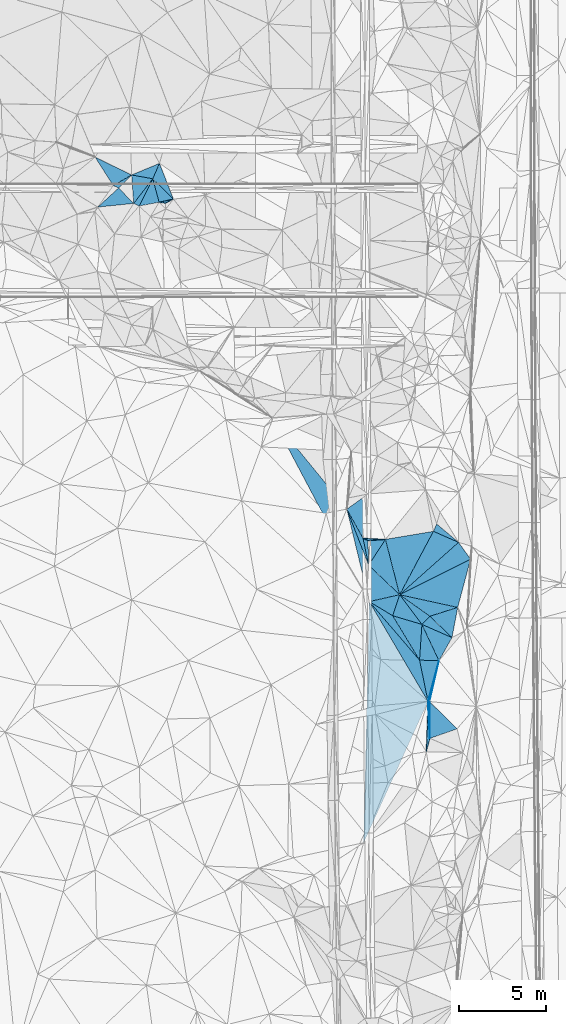
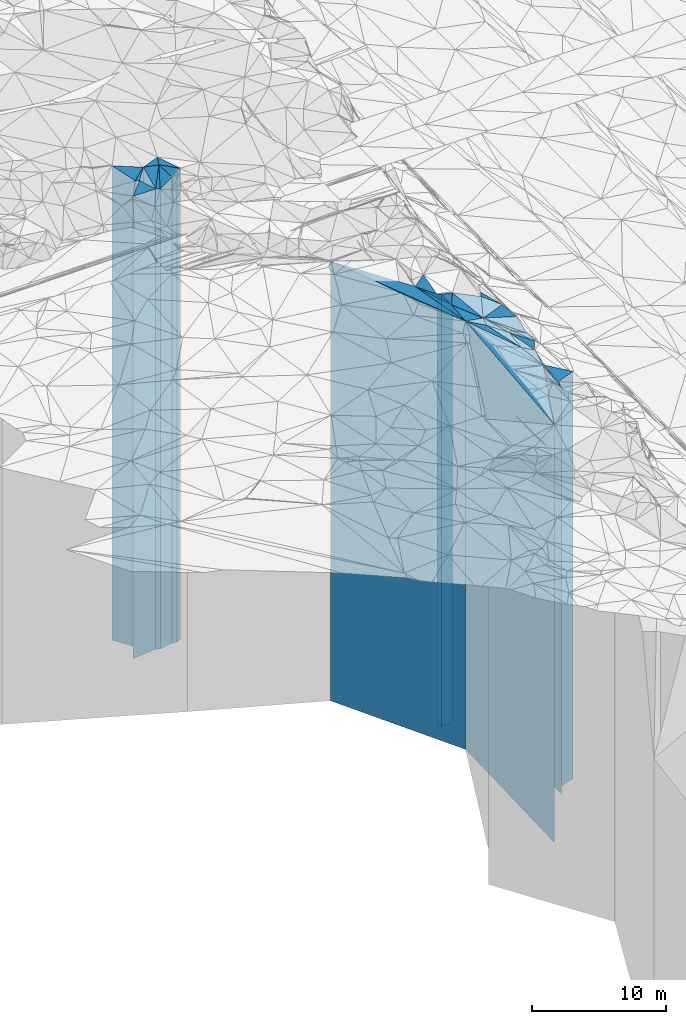
# One storey, part 206 of 275: 41 plates.
"""IFC2X3 building model written with IfcOpenShell, lengths in millimetres."""

import ifcopenshell
import ifcopenshell.guid

model = None  # the IFC model being written
_history = None  # IfcOwnerHistory: only IFC2X3 demands one
_inside = {}  # id of a spatial element -> (the spatial element, [elements in it])
_under = {}  # id of a project, library or spatial element -> (it, [spatial elements below it])
_declared = {}  # id of a project -> (the project, [libraries it declares])
_typed = {}  # id of a type object -> (the type object, [elements of that type])
_made_of = {}  # id of a material, layer set ... -> (it, [elements and type objects made of it])


def new_model(schema):
    """Start an empty IFC model of exactly this schema.

    Asked for "IFC4X3", IfcOpenShell would pick the latest addendum, in which some entities
    have other attributes; the version numbers below select the first issue.
    IFC2X3 requires an IfcOwnerHistory on every rooted entity: one is made here for all.
    """
    global model, _history
    if schema == "IFC4X3":
        model = ifcopenshell.file(schema_version=(4, 3, 0, 0))
    else:
        model = ifcopenshell.file(schema=schema)
    _inside.clear()
    _under.clear()
    _declared.clear()
    _typed.clear()
    _made_of.clear()
    _history = None
    if model.schema == "IFC2X3":
        org = make("IfcOrganization", Name="unknown")
        user = make(
            "IfcPersonAndOrganization",
            ThePerson=make("IfcPerson", FamilyName="unknown"),
            TheOrganization=org,
        )
        app = make(
            "IfcApplication",
            ApplicationDeveloper=org,
            Version="unknown",
            ApplicationFullName="unknown",
            ApplicationIdentifier="unknown",
        )
        _history = make(
            "IfcOwnerHistory",
            OwningUser=user,
            OwningApplication=app,
            ChangeAction="ADDED",
            CreationDate=0,
        )
    return model


def make(cls, **values):
    """One entity of the class cls with the attributes given. An attribute that is None is left unset."""
    return model.create_entity(
        cls, **{name: value for name, value in values.items() if value is not None}
    )


def rooted(cls, **values):
    """An entity with a GlobalId (a new one), such as an element, a storey or a relation."""
    return make(cls, GlobalId=ifcopenshell.guid.new(), OwnerHistory=_history, **values)


def si_unit(unit_type, name, prefix=None):
    """IfcSIUnit, for example si_unit("LENGTHUNIT", "METRE", prefix="MILLI")."""
    return make("IfcSIUnit", UnitType=unit_type, Prefix=prefix, Name=name)


def assignment(units):
    """IfcUnitAssignment: the units of a project."""
    return None if units is None else make("IfcUnitAssignment", Units=units)


def point(xyz):
    """IfcCartesianPoint."""
    return None if xyz is None else make("IfcCartesianPoint", Coordinates=xyz)


def direction(xyz):
    """IfcDirection."""
    return None if xyz is None else make("IfcDirection", DirectionRatios=xyz)


def frame(location, z_axis=None, x_axis=None):
    """IfcAxis2Placement3D, a coordinate frame: its origin and axes. An axis left out is left unset."""
    return make(
        "IfcAxis2Placement3D",
        Location=point(location),
        Axis=direction(z_axis),
        RefDirection=direction(x_axis),
    )


def origin_with_axes():
    """The frame at (0, 0, 0) with the z axis (0, 0, 1) and the x axis (1, 0, 0) written out."""
    return frame((0.0, 0.0, 0.0), z_axis=(0.0, 0.0, 1.0), x_axis=(1.0, 0.0, 0.0))


def place(relative_to, where):
    """IfcLocalPlacement: puts the frame where relative to a parent placement (None: the world)."""
    return make(
        "IfcLocalPlacement", PlacementRelTo=relative_to, RelativePlacement=where
    )


def context(
    kind, dimensions, precision=None, world=None, true_north=None, identifier=None
):
    """IfcGeometricRepresentationContext, for example the 3D "Model" context."""
    return make(
        "IfcGeometricRepresentationContext",
        ContextIdentifier=identifier,
        ContextType=kind,
        CoordinateSpaceDimension=dimensions,
        Precision=precision,
        WorldCoordinateSystem=world,
        TrueNorth=true_north,
    )


def subcontext(parent, identifier, kind, view, scale=None):
    """IfcGeometricRepresentationSubContext, for example "Body" below "Model"."""
    return make(
        "IfcGeometricRepresentationSubContext",
        ContextIdentifier=identifier,
        ContextType=kind,
        ParentContext=parent,
        TargetScale=scale,
        TargetView=view,
    )


def project(units=None, contexts=None):
    """IfcProject with its units and contexts."""
    return rooted(
        "IfcProject",
        Name="project",
        RepresentationContexts=contexts,
        UnitsInContext=assignment(units),
    )


def spatial(cls, under=None, at=None, **own):
    """A site, building, storey or space (cls), placed at a placement, below another one or the project."""
    s = rooted(cls, ObjectPlacement=at, **own)
    if under is not None:
        _under.setdefault(under.id(), (under, []))[1].append(s)
    return s


def faces_of(points, faces, orient=None, outer=None):
    """IfcFace entities. A face is a list of loops; a loop is a list of indices into points, from 0.

    orient and outer hold one flag for each loop. By default every Orientation is true, the
    first loop of a face is its IfcFaceOuterBound and the others are IfcFaceBound.
    """
    made = []
    for i, loops in enumerate(faces):
        bounds = []
        for j, loop in enumerate(loops):
            is_outer = j == 0 if outer is None else outer[i][j]
            bounds.append(
                make(
                    "IfcFaceOuterBound" if is_outer else "IfcFaceBound",
                    Bound=make("IfcPolyLoop", Polygon=[points[k] for k in loop]),
                    Orientation=True if orient is None else orient[i][j],
                )
            )
        made.append(make("IfcFace", Bounds=bounds))
    return made


def faceted_brep(points, faces, orient=None, outer=None, voids=None):
    """IfcFacetedBrep: a solid bounded by flat faces; with voids (closed shells), ...WithVoids."""
    shared = [point(p) for p in points]
    hull = make("IfcClosedShell", CfsFaces=faces_of(shared, faces, orient, outer))
    if voids is None:
        return make("IfcFacetedBrep", Outer=hull)
    return make(
        "IfcFacetedBrepWithVoids",
        Outer=hull,
        Voids=[
            make(cls, CfsFaces=faces_of(shared, fs, o, b)) for cls, fs, o, b in voids
        ],
    )


def shape(context_of_items, identifier, shape_type, items):
    """IfcShapeRepresentation: the items that make up one representation, for example the "Body"."""
    return make(
        "IfcShapeRepresentation",
        ContextOfItems=context_of_items,
        RepresentationIdentifier=identifier,
        RepresentationType=shape_type,
        Items=items,
    )


def material(Name=None, Category=None):
    """IfcMaterial."""
    return make("IfcMaterial", Name=Name, Category=Category)


def made_of(thing, what):
    """Note that an element or type object is made of a material, layer set ...; save() writes the relation."""
    if what is not None:
        _made_of.setdefault(what.id(), (what, []))[1].append(thing)
    return thing


def type_object(cls, material=None, **own):
    """A type object (cls), such as IfcWallType, which elements share."""
    return made_of(rooted(cls, **own), material)


def element(
    cls,
    number,
    at=None,
    inside=None,
    cuts=None,
    type_object=None,
    material=None,
    context=None,
    identifier="Body",
    shape_type=None,
    held_by="IfcProductDefinitionShape",
    body=None,
    shapes=None,
    **own,
):
    """One element of the class cls, such as IfcWall. Its Tag is "e" and its number.

    at: its placement. inside: the storey or other place that contains it. cuts: it is an
    opening in that element (IfcRelVoidsElement). A single representation is given by context,
    identifier, shape_type and body (its items); several are given by shapes. held_by: the class
    of the entity that holds the representations. save() writes the other relations.
    """
    e = rooted(cls, Tag="e%d" % number, ObjectPlacement=at, **own)
    if body is not None:
        shapes = [shape(context, identifier, shape_type, body)]
    if shapes is not None:
        e.Representation = make(held_by, Representations=shapes)
    if inside is not None:
        _inside.setdefault(inside.id(), (inside, []))[1].append(e)
    if cuts is not None:
        rooted(
            "IfcRelVoidsElement", RelatingBuildingElement=cuts, RelatedOpeningElement=e
        )
    if type_object is not None:
        _typed.setdefault(type_object.id(), (type_object, []))[1].append(e)
    return made_of(e, material)


def aggregate(whole, parts):
    """IfcRelAggregates: a whole, such as a stair, and the parts it consists of."""
    return rooted("IfcRelAggregates", RelatingObject=whole, RelatedObjects=parts)


def save(model, path):
    """Write the relations noted so far, then the file.

    IfcRelAggregates (storeys below a building ...), IfcRelContainedInSpatialStructure (elements
    in a storey), IfcRelDefinesByType, IfcRelAssociatesMaterial and IfcRelDeclares: one each for
    every whole, place, type object, material and project.
    """
    for whole, parts in _under.values():
        aggregate(whole, parts)
    for where, things in _inside.values():
        rooted(
            "IfcRelContainedInSpatialStructure",
            RelatedElements=things,
            RelatingStructure=where,
        )
    for kind, things in _typed.values():
        rooted("IfcRelDefinesByType", RelatedObjects=things, RelatingType=kind)
    for what, things in _made_of.values():
        rooted("IfcRelAssociatesMaterial", RelatedObjects=things, RelatingMaterial=what)
    for by, libraries in _declared.values():
        rooted("IfcRelDeclares", RelatingContext=by, RelatedDefinitions=libraries)
    model.write(path)


model = new_model("IFC2X3")

# Units and contexts
model_context = context("Model", 3, precision=1e-05, world=origin_with_axes())
body_context = subcontext(model_context, "Body", "Model", "MODEL_VIEW")
ifc_project = project(units=[si_unit("LENGTHUNIT", "METRE", prefix="MILLI"), si_unit("AREAUNIT", "SQUARE_METRE"), si_unit("VOLUMEUNIT", "CUBIC_METRE"), si_unit("MASSUNIT", "GRAM", prefix="KILO"), si_unit("TIMEUNIT", "SECOND"), si_unit("PLANEANGLEUNIT", "RADIAN"), si_unit("SOLIDANGLEUNIT", "STERADIAN"), si_unit("THERMODYNAMICTEMPERATUREUNIT", "DEGREE_CELSIUS"), si_unit("LUMINOUSINTENSITYUNIT", "LUMEN")], contexts=[model_context])

# Site, building, storey
site_placement = place(None, origin_with_axes())
site = spatial("IfcSite", under=ifc_project, at=site_placement, CompositionType="ELEMENT")
building_placement = place(site_placement, origin_with_axes())
building = spatial("IfcBuilding", under=site, at=building_placement, Name="Undefined", CompositionType="ELEMENT")
storey_placement = place(building_placement, origin_with_axes())
storey = spatial("IfcBuildingStorey", under=building, at=storey_placement, Name="Undefined", CompositionType="ELEMENT", Elevation=0.0)

# Plates
ifc_material = material()
plate_type_1 = type_object("IfcPlateType", PredefinedType="NOTDEFINED")
plate_1_placement = place(storey_placement, frame((-114818.365511907, 65655.9589159586, 29039.0), z_axis=(-0.702956168828358, -0.71123317182634, 0.0), x_axis=(-0.711233171826337, 0.702956168828361, 0.0)))
element("IfcPlate", 1, at=plate_1_placement, inside=storey, type_object=plate_type_1, material=ifc_material, Name="00", context=body_context, shape_type="Brep", body=[
    faceted_brep([(0.0, -21611.0, 1.45519152283669e-11), (458.48233032228, -21211.0, 700.780944824211), (458.48233032228, 21211.0, 700.780944824211), (0.0, 21211.0, 1.45519152283669e-11), (1665.71301269533, -21641.0, 5.0058588385582e-09), (1665.71301269533, 21211.0, 5.0058588385582e-09)], [[[0, 1, 2, 3]], [[1, 4, 5, 2]], [[4, 0, 3, 5]], [[5, 3, 2]], [[4, 1, 0]]]),
])
plate_type_2 = type_object("IfcPlateType", PredefinedType="NOTDEFINED")
plate_2_placement = place(storey_placement, frame((-117095.235738703, 65414.5837508538, 28749.0), z_axis=(0.417077766117321, 0.908870803255658, 0.0), x_axis=(0.908870803255661, -0.417077766117315, 0.0)))
element("IfcPlate", 2, at=plate_2_placement, inside=storey, type_object=plate_type_2, material=ifc_material, Name="00", context=body_context, shape_type="Brep", body=[
    faceted_brep([(2.91038304567337e-11, -20961.0, 1.81898940354586e-12), (403.593902587891, -21931.0, 1739.11242675781), (403.593902587891, 20921.0, 1739.11242675781), (0.0, 20921.0, 2.72848410531878e-12), (347.131103515654, -20921.0, -1.08957465272397e-09), (347.131103515654, 20921.0, -1.08957465272397e-09)], [[[0, 1, 2, 3]], [[1, 4, 5, 2]], [[4, 0, 3, 5]], [[5, 3, 2]], [[4, 1, 0]]]),
])
plate_type_3 = type_object("IfcPlateType", PredefinedType="NOTDEFINED")
plate_3_placement = place(storey_placement, frame((-115637.071651429, 65479.8332304102, 29039.0), z_axis=(0.156007657948378, 0.987755845673141, 0.0), x_axis=(0.987755845673141, -0.156007657948377, 0.0)))
element("IfcPlate", 3, at=plate_3_placement, inside=storey, type_object=plate_type_3, material=ifc_material, Name="00", context=body_context, shape_type="Brep", body=[
    faceted_brep([(-7.27595761418343e-12, -21211.0, 2.91038304567337e-11), (781.204833984375, -21611.0, 301.693603515632), (781.204833984375, 21211.0, 301.693603515632), (0.0, 21211.0, 1.45519152283669e-11), (368.917327880859, -21641.0, 2.83762346953154e-10), (368.917327880859, 21211.0, 2.83762346953154e-10)], [[[0, 1, 2, 3]], [[1, 4, 5, 2]], [[4, 0, 3, 5]], [[5, 3, 2]], [[4, 1, 0]]]),
])
plate_type_4 = type_object("IfcPlateType", PredefinedType="NOTDEFINED")
plate_4_placement = place(storey_placement, frame((-117214.984869905, 67045.4608601347, 29034.0), z_axis=(-0.438778550060447, -0.898595228123793, 0.0), x_axis=(-0.898595228123792, 0.43877855006045, 0.0)))
element("IfcPlate", 4, at=plate_4_placement, inside=storey, type_object=plate_type_4, material=ifc_material, Name="00", context=body_context, shape_type="Brep", body=[
    faceted_brep([(0.0, -21716.0, 7.27595761418343e-12), (680.314880371094, -21206.0, 1009.04492187501), (680.314880371094, 21206.0, 1009.04492187501), (-1.45519152283669e-11, 21206.0, 0.0), (2327.74560546872, -21956.0, -9.27684595808387e-09), (2327.74560546872, 21206.0, -9.27684595808387e-09)], [[[0, 1, 2, 3]], [[1, 4, 5, 2]], [[4, 0, 3, 5]], [[5, 3, 2]], [[4, 1, 0]]]),
])
plate_type_5 = type_object("IfcPlateType", PredefinedType="NOTDEFINED")
plate_5_placement = place(storey_placement, frame((-117214.984869905, 67045.4608601347, 29034.0), z_axis=(0.499781156994508, -0.866151715990467, 0.0), x_axis=(-0.866151715990473, -0.499781156994498, 0.0)))
element("IfcPlate", 5, at=plate_5_placement, inside=storey, type_object=plate_type_5, material=ifc_material, Name="00", context=body_context, shape_type="Brep", body=[
    faceted_brep([(0.0, -21716.0, 7.27595761418343e-12), (1014.98529052736, -21206.0, 273.138854980454), (1014.98529052736, 21206.0, 273.138854980454), (-1.45519152283669e-11, 21206.0, 0.0), (1216.96337890626, -21206.0, 8.73114913702011e-11), (1216.96337890626, 21206.0, 8.73114913702011e-11)], [[[0, 1, 2, 3]], [[1, 4, 5, 2]], [[4, 0, 3, 5]], [[5, 3, 2]], [[4, 1, 0]]]),
])
plate_type_6 = type_object("IfcPlateType", PredefinedType="NOTDEFINED")
plate_6_placement = place(storey_placement, frame((-116003.075894758, 66826.8821878965, 29239.0), z_axis=(0.702956168828362, 0.711233171826337, 0.0), x_axis=(0.711233171826337, -0.702956168828361, 0.0)))
element("IfcPlate", 6, at=plate_6_placement, inside=storey, type_object=plate_type_6, material=ifc_material, Name="00", context=body_context, shape_type="Brep", body=[
    faceted_brep([(0.0, -21441.0, -1.45519152283669e-11), (-344.837310791001, -21461.0, 898.714233398438), (-344.837310791001, 21411.0, 898.714233398438), (0.0, 21411.0, -1.45519152283669e-11), (1665.71301269533, -21411.0, 5.02768671140075e-09), (1665.71301269533, 21411.0, 5.02768671140075e-09)], [[[0, 1, 2, 3]], [[1, 4, 5, 2]], [[4, 0, 3, 5]], [[5, 3, 2]], [[4, 1, 0]]]),
])
plate_type_7 = type_object("IfcPlateType", PredefinedType="NOTDEFINED")
plate_7_placement = place(storey_placement, frame((-116003.075894758, 66826.8821878965, 29254.0), z_axis=(-0.915853187964777, 0.401513309984556, 0.0), x_axis=(0.401513309984556, 0.915853187964777, 0.0)))
element("IfcPlate", 7, at=plate_7_placement, inside=storey, type_object=plate_type_7, material=ifc_material, Name="00", context=body_context, shape_type="Brep", body=[
    faceted_brep([(0.0, -21426.0, 0.0), (-286.411621093746, -21496.0, 1197.69299316406), (-286.411621093746, 21426.0, 1197.69299316406), (0.0, 21426.0, 1.45519152283669e-11), (962.600646972667, -21446.0, 3.43425199389458e-09), (962.600646972667, 21426.0, 3.43425199389458e-09)], [[[0, 1, 2, 3]], [[1, 4, 5, 2]], [[4, 0, 3, 5]], [[5, 3, 2]], [[4, 1, 0]]]),
])
plate_type_8 = type_object("IfcPlateType", PredefinedType="NOTDEFINED")
plate_8_placement = place(storey_placement, frame((-115637.071651429, 65479.8332304102, 28749.0), z_axis=(-0.965013024768855, -0.2622019489372, 0.0), x_axis=(-0.262201948937199, 0.965013024768855, 0.0)))
element("IfcPlate", 8, at=plate_8_placement, inside=storey, type_object=plate_type_8, material=ifc_material, Name="00", context=body_context, shape_type="Brep", body=[
    faceted_brep([(0.0, -21501.0, -1.45519152283669e-11), (96.9276275634766, -20921.0, 1157.7586669922), (96.9276275634766, 20921.0, 1157.7586669922), (0.0, 20921.0, 2.72848410531878e-12), (1395.88684082031, -21931.0, 1.01863406598568e-09), (1395.88684082031, 20921.0, 1.01863406598568e-09)], [[[0, 1, 2, 3]], [[1, 4, 5, 2]], [[4, 0, 3, 5]], [[5, 3, 2]], [[4, 1, 0]]]),
])
plate_type_9 = type_object("IfcPlateType", PredefinedType="NOTDEFINED")
plate_9_placement = place(storey_placement, frame((-117095.235738703, 65414.5837508538, 28769.0), z_axis=(-0.71700159120324, -0.697071530197599, 0.0), x_axis=(-0.697071530197598, 0.717001591203241, 0.0)))
element("IfcPlate", 9, at=plate_9_placement, inside=storey, type_object=plate_type_9, material=ifc_material, Name="00", context=body_context, shape_type="Brep", body=[
    faceted_brep([(0.0, -20941.0, 7.27595761418343e-12), (1284.82470703124, -21141.0, 1624.72326660156), (1284.82470703124, 20941.0, 1624.72326660156), (7.27595761418343e-12, 20941.0, 0.0), (1237.13378906249, -21471.0, 1.41153577715158e-09), (1237.13378906249, 20941.0, 1.41153577715158e-09)], [[[0, 1, 2, 3]], [[1, 4, 5, 2]], [[4, 0, 3, 5]], [[5, 3, 2]], [[4, 1, 0]]]),
])
plate_type_10 = type_object("IfcPlateType", PredefinedType="NOTDEFINED")
plate_10_placement = place(storey_placement, frame((-116003.075894758, 66826.8821878965, 28769.0), z_axis=(-0.177495184991706, -0.984121668953976, 0.0), x_axis=(-0.984121668953979, 0.177495184991694, 0.0)))
element("IfcPlate", 10, at=plate_10_placement, inside=storey, type_object=plate_type_10, material=ifc_material, Name="00", context=body_context, shape_type="Brep", body=[
    faceted_brep([(-1.63709046319127e-11, -21911.0, 0.0), (824.141967773423, -20941.0, 1583.7265625), (824.141967773423, 20941.0, 1583.7265625), (7.27595761418343e-12, 20941.0, 0.0), (1231.46252441405, -21981.0, 2.39379005506635e-09), (1231.46252441405, 20941.0, 2.39379005506635e-09)], [[[0, 1, 2, 3]], [[1, 4, 5, 2]], [[4, 0, 3, 5]], [[5, 3, 2]], [[4, 1, 0]]]),
])
plate_type_11 = type_object("IfcPlateType", PredefinedType="NOTDEFINED")
plate_11_placement = place(storey_placement, frame((-101855.96370675, 42992.0417911178, 26139.0), z_axis=(-0.664530362433699, 0.747261264487687, 0.0), x_axis=(0.74726126448769, 0.664530362433695, 0.0)))
element("IfcPlate", 11, at=plate_11_placement, inside=storey, type_object=plate_type_11, material=ifc_material, Name="00", context=body_context, shape_type="Brep", body=[
    faceted_brep([(0.0, -20091.0, 0.0), (3861.19091796876, -19161.0, 1428.42724609378), (3861.19091796876, 18311.0, 1428.42724609378), (7.27595761418343e-12, 18311.0, 1.45519152283669e-11), (4516.01611328126, -18311.0, 1.22527126222849e-08), (4516.01611328126, 18311.0, 1.22527126222849e-08)], [[[0, 1, 2, 3]], [[1, 4, 5, 2]], [[4, 0, 3, 5]], [[5, 3, 2]], [[4, 1, 0]]]),
])
plate_type_12 = type_object("IfcPlateType", PredefinedType="NOTDEFINED")
plate_12_placement = place(storey_placement, frame((-99734.2828294801, 47046.3444753073, 26139.0), z_axis=(0.915035399072081, -0.403373547031778, 0.0), x_axis=(-0.403373547031776, -0.915035399072081, 0.0)))
element("IfcPlate", 12, at=plate_12_placement, inside=storey, type_object=plate_type_12, material=ifc_material, Name="00", context=body_context, shape_type="Brep", body=[
    faceted_brep([(0.0, -19251.0, 1.45519152283669e-11), (458.369964599603, -18311.0, 1571.36791992188), (458.369964599603, 18311.0, 1571.36791992188), (7.27595761418343e-12, 18311.0, 1.45519152283669e-11), (460.108673095696, -19161.0, 6.11180439591408e-10), (460.108673095696, 18311.0, 6.11180439591408e-10)], [[[0, 1, 2, 3]], [[1, 4, 5, 2]], [[4, 0, 3, 5]], [[5, 3, 2]], [[4, 1, 0]]]),
])
plate_type_13 = type_object("IfcPlateType", PredefinedType="NOTDEFINED")
plate_13_placement = place(storey_placement, frame((-101855.96370675, 42992.0417911178, 25764.0), z_axis=(0.213202765926486, 0.97700797366311, 0.0), x_axis=(0.97700797366311, -0.213202765926484, 0.0)))
element("IfcPlate", 13, at=plate_13_placement, inside=storey, type_object=plate_type_13, material=ifc_material, Name="00", context=body_context, shape_type="Brep", body=[
    faceted_brep([(2.18278728425503e-11, -20466.0, 0.0), (3535.49169921875, -17936.0, 2856.62377929688), (3535.49169921875, 17936.0, 2856.62377929688), (0.0, 17936.0, 0.0), (3406.25903320313, -18376.0, -4.47471393272281e-10), (3406.25903320313, 17936.0, -4.47471393272281e-10)], [[[0, 1, 2, 3]], [[1, 4, 5, 2]], [[4, 0, 3, 5]], [[5, 3, 2]], [[4, 1, 0]]]),
])
plate_type_14 = type_object("IfcPlateType", PredefinedType="NOTDEFINED")
plate_14_placement = place(storey_placement, frame((-103954.609665335, 46229.9246087185, 27354.0), z_axis=(0.421997696830674, 0.90659690263623, 0.0), x_axis=(0.906596902636231, -0.421997696830672, 0.0)))
element("IfcPlate", 14, at=plate_14_placement, inside=storey, type_object=plate_type_14, material=ifc_material, Name="00", context=body_context, shape_type="Brep", body=[
    faceted_brep([(-7.27595761418343e-12, -19796.0, -1.45519152283669e-11), (1193.77478027342, -19526.0, 483.530517578117), (1193.77478027342, 19526.0, 483.530517578117), (0.0, 19526.0, 0.0), (318.904388427734, -19776.0, 1.30057742353529e-10), (318.904388427734, 19526.0, 1.30057742353529e-10)], [[[0, 1, 2, 3]], [[1, 4, 5, 2]], [[4, 0, 3, 5]], [[5, 3, 2]], [[4, 1, 0]]]),
])
plate_type_15 = type_object("IfcPlateType", PredefinedType="NOTDEFINED")
plate_15_placement = place(storey_placement, frame((-101855.96370675, 42992.0417911178, 25764.0), z_axis=(-0.448189406004903, 0.89393862000977, 0.0), x_axis=(0.893938620009772, 0.4481894060049, 0.0)))
element("IfcPlate", 15, at=plate_15_placement, inside=storey, type_object=plate_type_15, material=ifc_material, Name="00", context=body_context, shape_type="Brep", body=[
    faceted_brep([(2.18278728425503e-11, -20466.0, 0.0), (4361.75390625, -18686.0, 1170.2567138672), (4361.75390625, 17936.0, 1170.2567138672), (0.0, 17936.0, 0.0), (4545.32714843749, -17936.0, 1.57306203618646e-08), (4545.32714843749, 17936.0, 1.57306203618646e-08)], [[[0, 1, 2, 3]], [[1, 4, 5, 2]], [[4, 0, 3, 5]], [[5, 3, 2]], [[4, 1, 0]]]),
])
plate_type_16 = type_object("IfcPlateType", PredefinedType="NOTDEFINED")
plate_16_placement = place(storey_placement, frame((-103954.609665335, 46229.9246087185, 27434.0), z_axis=(0.979015098103885, 0.203787727021626, 0.0), x_axis=(0.203787727021601, -0.97901509810389, 0.0)))
element("IfcPlate", 16, at=plate_16_placement, inside=storey, type_object=plate_type_16, material=ifc_material, Name="00", context=body_context, shape_type="Brep", body=[
    faceted_brep([(0.0, -19716.0, 0.0), (190.671478271484, -19696.0, 255.625488281235), (190.671478271484, 19606.0, 255.625488281235), (0.0, 19606.0, -1.45519152283669e-11), (1574.96032714844, -19606.0, -1.51339918375015e-09), (1574.96032714844, 19606.0, -1.51339918375015e-09)], [[[0, 1, 2, 3]], [[1, 4, 5, 2]], [[4, 0, 3, 5]], [[5, 3, 2]], [[4, 1, 0]]]),
])
plate_type_17 = type_object("IfcPlateType", PredefinedType="NOTDEFINED")
plate_17_placement = place(storey_placement, frame((-103664.468272729, 48763.6803136547, 27489.0), z_axis=(0.57987314498819, -0.8147067789834, 0.0), x_axis=(-0.814706778983403, -0.579873144988185, 0.0)))
element("IfcPlate", 17, at=plate_17_placement, inside=storey, type_object=plate_type_17, material=ifc_material, Name="00", context=body_context, shape_type="Brep", body=[
    faceted_brep([(7.27595761418343e-12, -19811.0, 0.0), (1705.63708496097, -19661.0, 1896.02270507813), (1705.63708496097, 19661.0, 1896.02270507813), (7.27595761418343e-12, 19661.0, 0.0), (1493.44201660157, -19703.0, 6.28642737865448e-09), (1493.44201660157, 19661.0, 6.28642737865448e-09)], [[[0, 1, 2, 3]], [[1, 4, 5, 2]], [[4, 0, 3, 5]], [[5, 3, 2]], [[4, 1, 0]]]),
])
plate_type_18 = type_object("IfcPlateType", PredefinedType="NOTDEFINED")
plate_18_placement = place(storey_placement, frame((-103633.652082786, 44688.0146793764, 27029.0), z_axis=(0.690281609304469, 0.723540807319139, 0.0), x_axis=(0.723540807319138, -0.690281609304471, 0.0)))
element("IfcPlate", 18, at=plate_18_placement, inside=storey, type_object=plate_type_18, material=ifc_material, Name="00", context=body_context, shape_type="Brep", body=[
    faceted_brep([(-1.45519152283669e-11, -20011.0, 0.0), (-320.7255859375, -19851.0, 1734.68591308594), (-320.7255859375, 19201.0, 1734.68591308594), (0.0, 19201.0, -1.09139364212751e-11), (2456.92895507811, -19201.0, 4.39467839896679e-09), (2456.92895507811, 19201.0, 4.39467839896679e-09)], [[[0, 1, 2, 3]], [[1, 4, 5, 2]], [[4, 0, 3, 5]], [[5, 3, 2]], [[4, 1, 0]]]),
])
plate_type_19 = type_object("IfcPlateType", PredefinedType="NOTDEFINED")
plate_19_placement = place(storey_placement, frame((-103954.609665335, 46229.9246087185, 27434.0), z_axis=(-0.874146413119837, -0.485662484066583, 0.0), x_axis=(-0.485662484066579, 0.874146413119839, 0.0)))
element("IfcPlate", 19, at=plate_19_placement, inside=storey, type_object=plate_type_19, material=ifc_material, Name="00", context=body_context, shape_type="Brep", body=[
    faceted_brep([(0.0, -19716.0, 0.0), (-1503.73205566405, -19606.0, 468.283874511733), (-1503.73205566405, 19606.0, 468.283874511733), (0.0, 19606.0, -1.45519152283669e-11), (1907.85974121094, -19758.0, 8.92032403498888e-09), (1907.85974121094, 19606.0, 8.92032403498888e-09)], [[[0, 1, 2, 3]], [[1, 4, 5, 2]], [[4, 0, 3, 5]], [[5, 3, 2]], [[4, 1, 0]]]),
])
plate_type_20 = type_object("IfcPlateType", PredefinedType="NOTDEFINED")
plate_20_placement = place(storey_placement, frame((-103633.652082786, 44688.0146793764, 27312.0), z_axis=(-0.93207009676024, -0.362277979906807, 0.0), x_axis=(-0.362277979906808, 0.93207009676024, 0.0)))
element("IfcPlate", 20, at=plate_20_placement, inside=storey, type_object=plate_type_20, material=ifc_material, Name="00", context=body_context, shape_type="Brep", body=[
    faceted_brep([(0.0, -19728.0, 0.0), (-1959.9278564453, -19484.0, 721.392944335938), (-1959.9278564453, 19484.0, 721.392944335938), (0.0, 19484.0, 0.0), (3443.58081054689, -19880.0, -1.01572368294001e-08), (3443.58081054689, 19484.0, -1.01572368294001e-08)], [[[0, 1, 2, 3]], [[1, 4, 5, 2]], [[4, 0, 3, 5]], [[5, 3, 2]], [[4, 1, 0]]]),
])
plate_type_21 = type_object("IfcPlateType", PredefinedType="NOTDEFINED")
plate_21_placement = place(storey_placement, frame((-101855.96370675, 42992.0417911178, 25984.0), z_axis=(0.578818290171517, 0.815456551241647, 0.0), x_axis=(0.815456551241646, -0.57881829017152, 0.0)))
element("IfcPlate", 21, at=plate_21_placement, inside=storey, type_object=plate_type_21, material=ifc_material, Name="00", context=body_context, shape_type="Brep", body=[
    faceted_brep([(0.0, -20246.0, 0.0), (3134.14379882811, -18156.0, 1334.06982421874), (3134.14379882811, 18156.0, 1334.06982421874), (-1.45519152283669e-11, 18156.0, -1.45519152283669e-11), (2130.02343749999, -19256.0, 5.39148459210992e-09), (2130.02343749999, 18156.0, 5.39148459210992e-09)], [[[0, 1, 2, 3]], [[1, 4, 5, 2]], [[4, 0, 3, 5]], [[5, 3, 2]], [[4, 1, 0]]]),
])
plate_type_22 = type_object("IfcPlateType", PredefinedType="NOTDEFINED")
plate_22_placement = place(storey_placement, frame((-99919.8785007401, 46625.3287430484, 26564.0), z_axis=(0.165355117087543, -0.986234092522138, 0.0), x_axis=(-0.986234092522138, -0.165355117087542, 0.0)))
element("IfcPlate", 22, at=plate_22_placement, inside=storey, type_object=plate_type_22, material=ifc_material, Name="00", context=body_context, shape_type="Brep", body=[
    faceted_brep([(-1.45519152283669e-11, -18736.0, -1.45519152283669e-11), (2510.2158203125, -19666.0, 3263.1298828125), (2510.2158203125, 18736.0, 3263.1298828125), (-5.91171556152403e-12, 18736.0, 1.45519152283669e-11), (2786.77221679688, -20316.0, 2.11002770811319e-09), (2786.77221679688, 18736.0, 2.11002770811319e-09)], [[[0, 1, 2, 3]], [[1, 4, 5, 2]], [[4, 0, 3, 5]], [[5, 3, 2]], [[4, 1, 0]]]),
])
plate_type_23 = type_object("IfcPlateType", PredefinedType="NOTDEFINED")
plate_23_placement = place(storey_placement, frame((-103633.652082786, 44688.0146793764, 27029.0), z_axis=(0.999837492120502, 0.0180274610021705, 0.0), x_axis=(0.0180274610021708, -0.999837492120502, 0.0)))
element("IfcPlate", 23, at=plate_23_placement, inside=storey, type_object=plate_type_23, material=ifc_material, Name="00", context=body_context, shape_type="Brep", body=[
    faceted_brep([(-1.45519152283669e-11, -20011.0, 0.0), (1727.74450683593, -19201.0, 1746.82543945311), (1727.74450683593, 19201.0, 1746.82543945311), (0.0, 19201.0, -1.09139364212751e-11), (2088.47436523436, -19767.0, 1.70257408171892e-09), (2088.47436523436, 19201.0, 1.70257408171892e-09)], [[[0, 1, 2, 3]], [[1, 4, 5, 2]], [[4, 0, 3, 5]], [[5, 3, 2]], [[4, 1, 0]]]),
])
plate_type_24 = type_object("IfcPlateType", PredefinedType="NOTDEFINED")
plate_24_placement = place(storey_placement, frame((-101855.96370675, 42992.0417911178, 26654.0), z_axis=(0.949598887993364, -0.313467624997809, 0.0), x_axis=(-0.313467624997813, -0.949598887993363, 0.0)))
element("IfcPlate", 24, at=plate_24_placement, inside=storey, type_object=plate_type_24, material=ifc_material, Name="00", context=body_context, shape_type="Brep", body=[
    faceted_brep([(-3.63797880709171e-12, -19576.0, 0.0), (1213.42675781251, -18826.0, 1744.38977050781), (1213.42675781251, 18826.0, 1744.38977050781), (-1.45519152283669e-11, 18826.0, -7.27595761418343e-12), (1267.31994628906, -19786.0, -1.04773789644241e-09), (1267.31994628906, 18826.0, -1.04773789644241e-09)], [[[0, 1, 2, 3]], [[1, 4, 5, 2]], [[4, 0, 3, 5]], [[5, 3, 2]], [[4, 1, 0]]]),
])
plate_type_25 = type_object("IfcPlateType", PredefinedType="NOTDEFINED")
plate_25_placement = place(storey_placement, frame((-99604.0225451746, 39209.6403046542, 26214.0), z_axis=(-0.870979103580604, 0.491320059763417, 0.0), x_axis=(0.491320059763419, 0.870979103580603, 0.0)))
element("IfcPlate", 25, at=plate_25_placement, inside=storey, type_object=plate_type_25, material=ifc_material, Name="00", context=body_context, shape_type="Brep", body=[
    faceted_brep([(-7.27595761418343e-12, -18626.0, 1.45519152283669e-11), (1335.08081054688, -19266.0, 1873.51525878908), (1335.08081054688, 18386.0, 1873.51525878908), (-7.27595761418343e-12, 18386.0, 1.45519152283669e-11), (1522.00524902344, -18386.0, -2.7212081477046e-09), (1522.00524902344, 18386.0, -2.7212081477046e-09)], [[[0, 1, 2, 3]], [[1, 4, 5, 2]], [[4, 0, 3, 5]], [[5, 3, 2]], [[4, 1, 0]]]),
])
plate_type_26 = type_object("IfcPlateType", PredefinedType="NOTDEFINED")
plate_26_placement = place(storey_placement, frame((-100119.022110128, 41759.1452464219, 26214.0), z_axis=(0.711168789384194, -0.703021303379791, 0.0), x_axis=(-0.703021303379797, -0.711168789384188, 0.0)))
element("IfcPlate", 26, at=plate_26_placement, inside=storey, type_object=plate_type_26, material=ifc_material, Name="00", context=body_context, shape_type="Brep", body=[
    faceted_brep([(0.0, -19026.0, 0.0), (-17.3909053802345, -18386.0, 1758.46459960938), (-17.3909053802345, 18386.0, 1758.46459960938), (-7.27595761418343e-12, 18386.0, 1.45519152283669e-11), (655.515075683586, -19266.0, 1.07684172689915e-09), (655.515075683586, 18386.0, 1.07684172689915e-09)], [[[0, 1, 2, 3]], [[1, 4, 5, 2]], [[4, 0, 3, 5]], [[5, 3, 2]], [[4, 1, 0]]]),
])
plate_type_27 = type_object("IfcPlateType", PredefinedType="NOTDEFINED")
plate_27_placement = place(storey_placement, frame((-100579.863165295, 41292.9633914851, 26534.0), z_axis=(-0.711168789384194, 0.703021303379791, 0.0), x_axis=(0.703021303379797, 0.711168789384188, 0.0)))
element("IfcPlate", 27, at=plate_27_placement, inside=storey, type_object=plate_type_27, material=ifc_material, Name="00", context=body_context, shape_type="Brep", body=[
    faceted_brep([(7.27595761418343e-12, -18946.0, 1.45519152283669e-11), (311.205657958992, -19696.0, 2102.01123046876), (311.205657958992, 18706.0, 2102.01123046876), (7.27595761418343e-12, 18706.0, 1.45519152283669e-11), (655.515075683594, -18706.0, 1.07684172689915e-09), (655.515075683594, 18706.0, 1.07684172689915e-09)], [[[0, 1, 2, 3]], [[1, 4, 5, 2]], [[4, 0, 3, 5]], [[5, 3, 2]], [[4, 1, 0]]]),
])
plate_type_28 = type_object("IfcPlateType", PredefinedType="NOTDEFINED")
plate_28_placement = place(storey_placement, frame((-100579.863165295, 41292.9633914851, 26614.0), z_axis=(-0.283994080137235, -0.958826033463321, 0.0), x_axis=(-0.958826033463322, 0.283994080137232, 0.0)))
element("IfcPlate", 28, at=plate_28_placement, inside=storey, type_object=plate_type_28, material=ifc_material, Name="00", context=body_context, shape_type="Brep", body=[
    faceted_brep([(1.45519152283669e-11, -18866.0, -3.63797880709171e-12), (-451.736206054702, -18786.0, 2000.45605468749), (-451.736206054702, 18786.0, 2000.45605468749), (0.0, 18786.0, -1.81898940354586e-12), (1745.22204589845, -19826.0, 2.29192664846778e-09), (1745.22204589845, 18786.0, 2.29192664846778e-09)], [[[0, 1, 2, 3]], [[1, 4, 5, 2]], [[4, 0, 3, 5]], [[5, 3, 2]], [[4, 1, 0]]]),
])
plate_type_29 = type_object("IfcPlateType", PredefinedType="NOTDEFINED")
plate_29_placement = place(storey_placement, frame((-101855.96370675, 42992.0417911178, 27029.0), z_axis=(0.219860841068546, -0.975531245304133, 0.0), x_axis=(-0.975531245304133, -0.219860841068545, 0.0)))
element("IfcPlate", 29, at=plate_29_placement, inside=storey, type_object=plate_type_29, material=ifc_material, Name="00", context=body_context, shape_type="Brep", body=[
    faceted_brep([(0.0, -19201.0, -1.09139364212751e-11), (652.133850097656, -19411.0, 1086.65612792968), (652.133850097656, 19201.0, 1086.65612792968), (0.0, 19201.0, -1.09139364212751e-11), (1783.68298339845, -19767.0, -4.03088051825762e-09), (1783.68298339845, 19201.0, -4.03088051825762e-09)], [[[0, 1, 2, 3]], [[1, 4, 5, 2]], [[4, 0, 3, 5]], [[5, 3, 2]], [[4, 1, 0]]]),
])
plate_type_30 = type_object("IfcPlateType", PredefinedType="NOTDEFINED")
plate_30_placement = place(storey_placement, frame((-102253.227499946, 41788.5961219596, 26614.0), z_axis=(-0.51712680820716, -0.855908794342876, 0.0), x_axis=(-0.855908794342876, 0.51712680820716, 0.0)))
element("IfcPlate", 30, at=plate_30_placement, inside=storey, type_object=plate_type_30, material=ifc_material, Name="00", context=body_context, shape_type="Brep", body=[
    faceted_brep([(-1.45519152283669e-11, -19826.0, 3.63797880709171e-12), (-2631.25854492188, -18786.0, 1380.19165039064), (-2631.25854492188, 18786.0, 1380.19165039064), (0.0, 18786.0, -1.81898940354586e-12), (1568.82922363281, -20182.0, -5.95537130720913e-09), (1568.82922363281, 18786.0, -5.95537130720913e-09)], [[[0, 1, 2, 3]], [[1, 4, 5, 2]], [[4, 0, 3, 5]], [[5, 3, 2]], [[4, 1, 0]]]),
])
plate_type_31 = type_object("IfcPlateType", PredefinedType="NOTDEFINED")
plate_31_placement = place(storey_placement, frame((-100228.947719388, 36876.6476928712, 26334.0), z_axis=(0.063158604023255, 0.998003502367519, 0.0), x_axis=(0.99800350236752, -0.0631586040232376, 0.0)))
element("IfcPlate", 31, at=plate_31_placement, inside=storey, type_object=plate_type_31, material=ifc_material, Name="00", context=body_context, shape_type="Brep", body=[
    faceted_brep([(0.0, -18724.0, 3.63797880709171e-12), (476.32894897458, -18506.0, 2367.80419921875), (476.32894897458, 18506.0, 2367.80419921875), (0.0, 18506.0, 1.45519152283669e-11), (84.5340194702148, -18736.0, 1.81898940354586e-11), (84.5340194702148, 18506.0, 1.81898940354586e-11)], [[[0, 1, 2, 3]], [[1, 4, 5, 2]], [[4, 0, 3, 5]], [[5, 3, 2]], [[4, 1, 0]]]),
])
plate_type_32 = type_object("IfcPlateType", PredefinedType="NOTDEFINED")
plate_32_placement = place(storey_placement, frame((-99604.0225451746, 39209.6403046542, 26334.0), z_axis=(-0.033239287007604, -0.999447422228516, 0.0), x_axis=(-0.999447422228516, 0.0332392870076034, 0.0)))
element("IfcPlate", 32, at=plate_32_placement, inside=storey, type_object=plate_type_32, material=ifc_material, Name="00", context=body_context, shape_type="Brep", body=[
    faceted_brep([(0.0, -18506.0, 1.45519152283669e-11), (547.032836914077, -18724.0, 2352.47558593749), (547.032836914077, 18506.0, 2352.47558593749), (0.0, 18506.0, 1.45519152283669e-11), (1111.43603515626, -19066.0, 3.52883944287896e-09), (1111.43603515626, 18506.0, 3.52883944287896e-09)], [[[0, 1, 2, 3]], [[1, 4, 5, 2]], [[4, 0, 3, 5]], [[5, 3, 2]], [[4, 1, 0]]]),
])
plate_type_33 = type_object("IfcPlateType", PredefinedType="NOTDEFINED")
plate_33_placement = place(storey_placement, frame((-100144.582474531, 36871.3086423841, 26339.0), z_axis=(-0.063158604023255, -0.998003502367519, 0.0), x_axis=(-0.998003502367519, 0.0631586040232485, 0.0)))
element("IfcPlate", 33, at=plate_33_placement, inside=storey, type_object=plate_type_33, material=ifc_material, Name="00", context=body_context, shape_type="Brep", body=[
    faceted_brep([(0.0, -18731.0, 0.0), (-158.634368896499, -18511.0, 2104.12329101563), (-158.634368896499, 18511.0, 2104.12329101563), (1.45519152283669e-11, 18511.0, -1.45519152283669e-11), (84.5340194702148, -18719.0, 1.45519152283669e-11), (84.5340194702148, 18511.0, 1.45519152283669e-11)], [[[0, 1, 2, 3]], [[1, 4, 5, 2]], [[4, 0, 3, 5]], [[5, 3, 2]], [[4, 1, 0]]]),
])
plate_type_34 = type_object("IfcPlateType", PredefinedType="NOTDEFINED")
plate_34_placement = place(storey_placement, frame((-100119.158317883, 34761.3670289126, 26339.0), z_axis=(-0.330860922101641, 0.94367952728988, 0.0), x_axis=(0.943679527289882, 0.330860922101636, 0.0)))
element("IfcPlate", 34, at=plate_34_placement, inside=storey, type_object=plate_type_34, material=ifc_material, Name="00", context=body_context, shape_type="Brep", body=[
    faceted_brep([(1.45519152283669e-11, -18511.0, -1.45519152283669e-11), (674.104980468765, -18731.0, 1999.5205078125), (674.104980468765, 18511.0, 1999.5205078125), (1.45519152283669e-11, 18511.0, -1.45519152283669e-11), (1645.14440917969, -18551.0, 7.17409420758486e-09), (1645.14440917969, 18511.0, 7.17409420758486e-09)], [[[0, 1, 2, 3]], [[1, 4, 5, 2]], [[4, 0, 3, 5]], [[5, 3, 2]], [[4, 1, 0]]]),
])
plate_type_35 = type_object("IfcPlateType", PredefinedType="NOTDEFINED")
plate_35_placement = place(storey_placement, frame((-100119.158317883, 34761.3670289126, 26318.0), z_axis=(-0.99865575489588, -0.051833224994598, 0.0), x_axis=(-0.0518332249945943, 0.99865575489588, 0.0)))
element("IfcPlate", 35, at=plate_35_placement, inside=storey, type_object=plate_type_35, material=ifc_material, Name="00", context=body_context, shape_type="Brep", body=[
    faceted_brep([(0.0, -18532.0, 1.45519152283669e-11), (-757.769165039063, -18490.0, 252.479553222671), (-757.769165039063, 18490.0, 252.479553222671), (0.0, 18490.0, 1.45519152283669e-11), (2118.1279296875, -18740.0, 3.63797880709171e-09), (2118.1279296875, 18490.0, 3.63797880709171e-09)], [[[0, 1, 2, 3]], [[1, 4, 5, 2]], [[4, 0, 3, 5]], [[5, 3, 2]], [[4, 1, 0]]]),
])
plate_type_36 = type_object("IfcPlateType", PredefinedType="NOTDEFINED")
plate_36_placement = place(storey_placement, frame((-103596.002192829, 42599.8797494003, 27312.0), z_axis=(-0.971813561842253, -0.235750717961736, 0.0), x_axis=(-0.235750717961732, 0.971813561842254, 0.0)))
element("IfcPlate", 36, at=plate_36_placement, inside=storey, type_object=plate_type_36, material=ifc_material, Name="00", context=body_context, shape_type="Brep", body=[
    faceted_brep([(-1.45519152283669e-11, -19484.0, -1.45519152283669e-11), (11534.0009765625, -20509.0, 2925.33789062499), (11534.0009765625, 19484.0, 2925.33789062499), (0.0, 19484.0, 0.0), (5451.45068359374, -19880.0, 1.76805770024657e-08), (5451.45068359374, 19484.0, 1.76805770024657e-08)], [[[0, 1, 2, 3]], [[1, 4, 5, 2]], [[4, 0, 3, 5]], [[5, 3, 2]], [[4, 1, 0]]]),
])
plate_type_37 = type_object("IfcPlateType", PredefinedType="NOTDEFINED")
plate_37_placement = place(storey_placement, frame((-98528.0215572814, 42265.8179621298, 25984.0), z_axis=(0.303445802023805, -0.952848700074744, 0.0), x_axis=(-0.952848700074744, -0.303445802023804, 0.0)))
element("IfcPlate", 37, at=plate_37_placement, inside=storey, type_object=plate_type_37, material=ifc_material, Name="00", context=body_context, shape_type="Brep", body=[
    faceted_brep([(1.45519152283669e-11, -18156.0, 0.0), (837.859741210938, -18616.0, 1549.35180664063), (837.859741210938, 18156.0, 1549.35180664063), (-1.45519152283669e-11, 18156.0, -1.45519152283669e-11), (1669.73046875, -19256.0, -1.80443748831749e-09), (1669.73046875, 18156.0, -1.80443748831749e-09)], [[[0, 1, 2, 3]], [[1, 4, 5, 2]], [[4, 0, 3, 5]], [[5, 3, 2]], [[4, 1, 0]]]),
])
plate_type_38 = type_object("IfcPlateType", PredefinedType="NOTDEFINED")
plate_38_placement = place(storey_placement, frame((-100228.947719388, 36876.6476928712, 26443.0), z_axis=(-0.979622551813606, -0.200847344961786, 0.0), x_axis=(-0.200847344961782, 0.979622551813607, 0.0)))
element("IfcPlate", 38, at=plate_38_placement, inside=storey, type_object=plate_type_38, material=ifc_material, Name="00", context=body_context, shape_type="Brep", body=[
    faceted_brep([(0.0, -18615.0, 0.0), (6282.87109375, -20353.0, 2148.94653320313), (6282.87109375, 18615.0, 2148.94653320313), (0.0, 18615.0, 0.0), (2419.23364257813, -18957.0, -1.0433723218739e-08), (2419.23364257813, 18615.0, -1.0433723218739e-08)], [[[0, 1, 2, 3]], [[1, 4, 5, 2]], [[4, 0, 3, 5]], [[5, 3, 2]], [[4, 1, 0]]]),
])
plate_type_39 = type_object("IfcPlateType", PredefinedType="NOTDEFINED")
plate_39_placement = place(storey_placement, frame((-102668.288377088, 46164.5216775725, 27354.0), z_axis=(0.069201667006713, -0.997602691096757, 0.0), x_axis=(-0.997602691096757, -0.0692016670067101, 0.0)))
element("IfcPlate", 39, at=plate_39_placement, inside=storey, type_object=plate_type_39, material=ifc_material, Name="00", context=body_context, shape_type="Brep", body=[
    faceted_brep([(0.0, -19526.0, 0.0), (1065.22619628906, -19686.0, 1406.16259765625), (1065.22619628906, 19526.0, 1406.16259765625), (0.0, 19526.0, 0.0), (999.599914550781, -19776.0, 1.81171344593167e-09), (999.599914550781, 19526.0, 1.81171344593167e-09)], [[[0, 1, 2, 3]], [[1, 4, 5, 2]], [[4, 0, 3, 5]], [[5, 3, 2]], [[4, 1, 0]]]),
])
plate_type_40 = type_object("IfcPlateType", PredefinedType="NOTDEFINED")
plate_40_placement = place(storey_placement, frame((-100579.863165295, 41292.9633914851, 26334.0), z_axis=(0.997831646995908, -0.0658179629997315, 0.0), x_axis=(-0.0658179629997304, -0.997831646995908, 0.0)))
element("IfcPlate", 40, at=plate_40_placement, inside=storey, type_object=plate_type_40, material=ifc_material, Name="00", context=body_context, shape_type="Brep", body=[
    faceted_brep([(0.0, -19146.0, -1.45519152283669e-11), (2014.57788085937, -18506.0, 1110.84472656249), (2014.57788085937, 18506.0, 1110.84472656249), (0.0, 18506.0, 1.45519152283669e-11), (2050.82666015625, -19066.0, 3.95812094211578e-09), (2050.82666015625, 18506.0, 3.95812094211578e-09)], [[[0, 1, 2, 3]], [[1, 4, 5, 2]], [[4, 0, 3, 5]], [[5, 3, 2]], [[4, 1, 0]]]),
])
plate_type_41 = type_object("IfcPlateType", PredefinedType="NOTDEFINED")
plate_41_placement = place(storey_placement, frame((-103923.095024849, 28774.71232621, 26443.0), z_axis=(-0.909881470575559, 0.414868303806472, 0.0), x_axis=(0.414868303806472, 0.909881470575558, 0.0)))
element("IfcPlate", 41, at=plate_41_placement, inside=storey, type_object=plate_type_41, material=ifc_material, Name="00", context=body_context, shape_type="Brep", body=[
    faceted_brep([(-7.27595761418343e-12, -19416.0, 1.45519152283669e-11), (12714.9638671875, -20353.0, 5438.00781250001), (12714.9638671875, 18615.0, 5438.00781250001), (0.0, 18615.0, 0.0), (8904.38574218749, -18615.0, -3.8038706406951e-08), (8904.38574218749, 18615.0, -3.8038706406951e-08)], [[[0, 1, 2, 3]], [[1, 4, 5, 2]], [[4, 0, 3, 5]], [[5, 3, 2]], [[4, 1, 0]]]),
])

save(model, "model.ifc")
